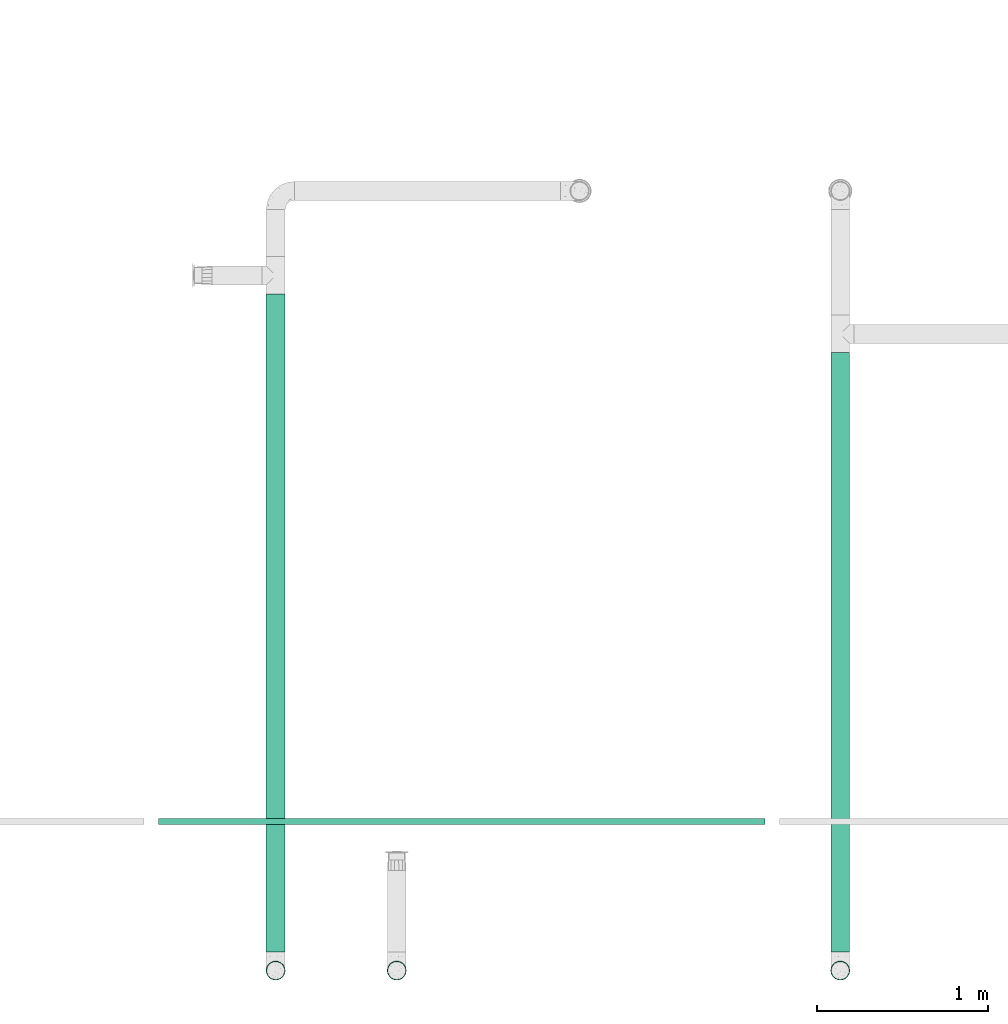
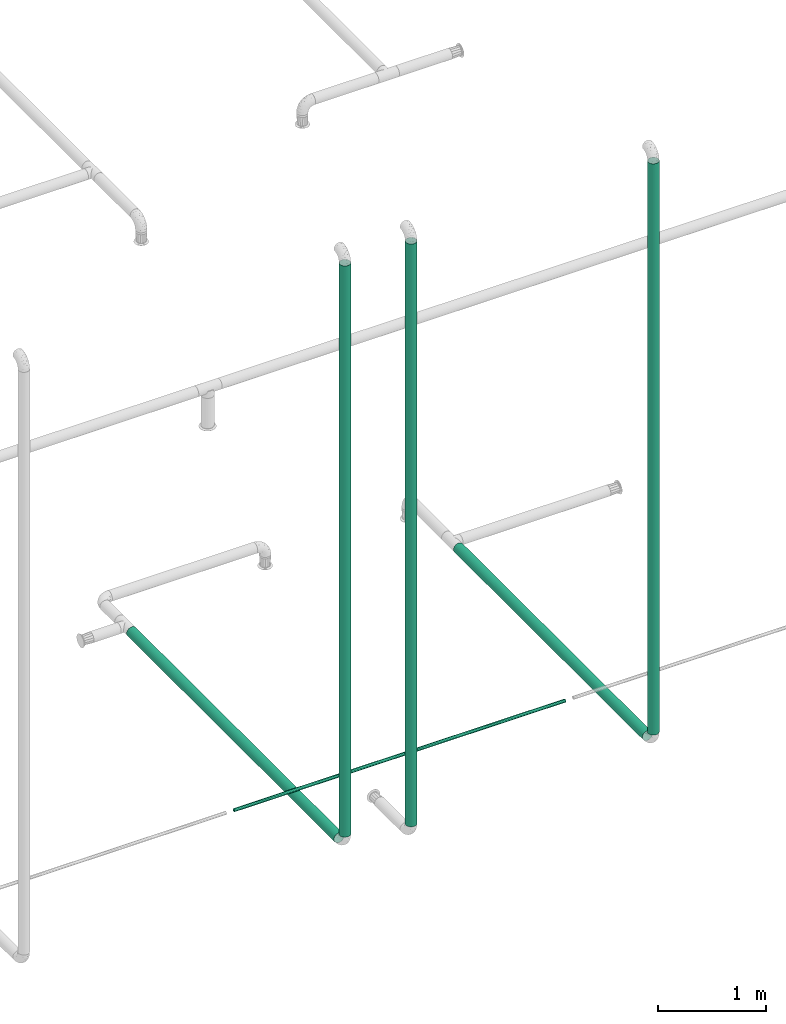
# One storey, part 14 of 123: 6 flow segments.
"""IFC2X3 building model written with IfcOpenShell, lengths in millimetres."""

from ifc_helpers import new_model, entity, si_unit, converted_unit, derived_unit, direction, frame, origin_with_axes, origin_2d_with_axis, place, context, subcontext, project, spatial, hollow_circle, extrude, source, transform, mapped, material, layer, layer_set, layer_usage, type_object, element, save


model = new_model("IFC2X3")

# Units and contexts
model_context = context("Model", 3, precision=1e-05, world=origin_with_axes(), true_north=direction((0.0, 1.0)))
body_context = subcontext(model_context, "Body", "Model", "MODEL_VIEW")
ifc_project = project(units=[si_unit("AREAUNIT", "SQUARE_METRE"), si_unit("VOLUMEUNIT", "CUBIC_METRE", prefix="DECI"), si_unit("TIMEUNIT", "SECOND"), si_unit("THERMODYNAMICTEMPERATUREUNIT", "DEGREE_CELSIUS"), si_unit("PRESSUREUNIT", "PASCAL"), si_unit("MASSUNIT", "GRAM", prefix="KILO"), si_unit("LENGTHUNIT", "METRE", prefix="MILLI"), si_unit("POWERUNIT", "WATT"), si_unit("ELECTRICCURRENTUNIT", "AMPERE"), si_unit("ELECTRICVOLTAGEUNIT", "VOLT"), derived_unit("VOLUMETRICFLOWRATEUNIT", [(si_unit("VOLUMEUNIT", "CUBIC_METRE", prefix="DECI"), 1), (si_unit("TIMEUNIT", "SECOND"), -1)]), derived_unit("LINEARVELOCITYUNIT", [(si_unit("LENGTHUNIT", "METRE"), 1), (si_unit("TIMEUNIT", "SECOND"), -1)]), derived_unit("MASSDENSITYUNIT", [(si_unit("MASSUNIT", "GRAM", prefix="KILO"), 1), (si_unit("VOLUMEUNIT", "CUBIC_METRE"), -1)]), converted_unit("PLANEANGLEUNIT", "DEGREE", entity("IfcRatioMeasure", 0.01745), si_unit("PLANEANGLEUNIT", "RADIAN"), dimensions=[0, 0, 0, 0, 0, 0, 0])], contexts=[model_context])

# Site, building, storey
site_placement = place(None, origin_with_axes())
site = spatial("IfcSite", under=ifc_project, at=site_placement, CompositionType="ELEMENT")
building_placement = place(site_placement, origin_with_axes())
building = spatial("IfcBuilding", under=site, at=building_placement, Name="mc-building", CompositionType="ELEMENT")
storey_placement = place(building_placement, origin_with_axes())
storey = spatial("IfcBuildingStorey", under=building, at=storey_placement, Name="1. Korrus", CompositionType="ELEMENT", Elevation=0.0)

# Flow segments
ifc_material_1 = material(Name="FZ1")
ifc_layer_1 = layer(ifc_material_1, 0.0)
ifc_layer_set_1 = layer_set([ifc_layer_1], Name="FZ1")
ifc_layer_usage_1 = layer_usage(ifc_layer_set_1, "AXIS1", "POSITIVE", 0.0)
duct_segment_type_1 = type_object("IfcDuctSegmentType", Name="Safe", PredefinedType="RIGIDSEGMENT")
shared_shape_1 = source(origin_with_axes(), body_context, "Body", "SweptSolid", [
    extrude(hollow_circle(Radius=55.0, WallThickness=2.0, at=origin_2d_with_axis()), frame((0.0, 0.0, 0.0), z_axis=(1.0, 0.0, 0.0), x_axis=(0.0, 1.0, 0.0)), (0.0, 0.0, 1.0), 6595.0),
])
flow_segment_1_placement = place(storey_placement, frame((27194.49649, -687.64676, 2410.0), z_axis=(0.0, 1.0, 0.0), x_axis=(0.0, 0.0, 1.0)))
element("IfcFlowSegment", 1, at=flow_segment_1_placement, inside=storey, type_object=duct_segment_type_1, material=ifc_layer_usage_1, Name="Safe", context=body_context, shape_type="MappedRepresentation", body=[
    mapped(shared_shape_1, transform((0.0, 0.0, 0.0), scale=1.0)),
])
duct_segment_type_2 = type_object("IfcDuctSegmentType", PredefinedType="RIGIDSEGMENT")
shared_shape_2 = source(origin_with_axes(), body_context, "Body", "SweptSolid", [
    extrude(hollow_circle(Radius=55.0, WallThickness=2.0, at=origin_2d_with_axis()), frame((0.0, 0.0, 0.0), z_axis=(1.0, 0.0, 0.0), x_axis=(0.0, 1.0, 0.0)), (0.0, 0.0, 1.0), 3844.9),
])
flow_segment_2_placement = place(storey_placement, frame((26486.51753, -577.64676, 2430.0), z_axis=(0.0, 0.0, 1.0), x_axis=(0.0, 1.0, 0.0)))
element("IfcFlowSegment", 2, at=flow_segment_2_placement, inside=storey, type_object=duct_segment_type_2, material=ifc_layer_usage_1, context=body_context, shape_type="MappedRepresentation", body=[
    mapped(shared_shape_2, transform((0.0, 0.0, 0.0), scale=1.0)),
])
shared_shape_3 = source(origin_with_axes(), body_context, "Body", "SweptSolid", [
    extrude(hollow_circle(Radius=55.0, WallThickness=2.0, at=origin_2d_with_axis()), frame((0.0, 0.0, 0.0), z_axis=(1.0, 0.0, 0.0), x_axis=(0.0, 1.0, 0.0)), (0.0, 0.0, 1.0), 6465.0),
])
for number, where, z_axis, x_axis in (
    (3, (26486.51753, -687.64676, 2540.0), (0.0, 1.0, 0.0), (0.0, 0.0, 1.0)),
    (4, (29788.00747, -687.64676, 2540.0), (0.0, 1.0, 0.0), (0.0, 0.0, 1.0)),
):
    element("IfcFlowSegment", number, at=place(storey_placement, frame(where, z_axis=z_axis, x_axis=x_axis)), inside=storey, type_object=duct_segment_type_2, material=ifc_layer_usage_1, context=body_context, shape_type="MappedRepresentation", body=[
        mapped(shared_shape_3, transform((0.0, 0.0, 0.0), scale=1.0)),
    ])
shared_shape_4 = source(origin_with_axes(), body_context, "Body", "SweptSolid", [
    extrude(hollow_circle(Radius=55.0, WallThickness=2.0, at=origin_2d_with_axis()), frame((0.0, 0.0, 0.0), z_axis=(1.0, 0.0, 0.0), x_axis=(0.0, 1.0, 0.0)), (0.0, 0.0, 1.0), 3503.0),
])
flow_segment_3_placement = place(storey_placement, frame((29788.00747, -577.64676, 2430.0), z_axis=(0.0, 0.0, 1.0), x_axis=(0.0, 1.0, 0.0)))
element("IfcFlowSegment", 5, at=flow_segment_3_placement, inside=storey, type_object=duct_segment_type_2, material=ifc_layer_usage_1, context=body_context, shape_type="MappedRepresentation", body=[
    mapped(shared_shape_4, transform((0.0, 0.0, 0.0), scale=1.0)),
])
ifc_material_2 = material(Name="Steel")
ifc_layer_2 = layer(ifc_material_2, 0.0)
ifc_layer_set_2 = layer_set([ifc_layer_2], Name="Steel")
ifc_layer_usage_2 = layer_usage(ifc_layer_set_2, "AXIS1", "POSITIVE", 0.0)
pipe_segment_type = type_object("IfcPipeSegmentType", PredefinedType="RIGIDSEGMENT")
shared_shape_5 = source(origin_with_axes(), body_context, "Body", "SweptSolid", [
    extrude(hollow_circle(Radius=17.5, WallThickness=2.0, at=origin_2d_with_axis()), frame((0.0, 0.0, 0.0), z_axis=(1.0, 0.0, 0.0), x_axis=(0.0, 1.0, 0.0)), (0.0, 0.0, 1.0), 3546.3),
])
flow_segment_4_placement = place(storey_placement, frame((25800.21447, 185.02869, 2518.78858), z_axis=(0.0, 0.0, 1.0), x_axis=(1.0, 0.0, 0.0)))
element("IfcFlowSegment", 6, at=flow_segment_4_placement, inside=storey, type_object=pipe_segment_type, material=ifc_layer_usage_2, context=body_context, shape_type="MappedRepresentation", body=[
    mapped(shared_shape_5, transform((0.0, 0.0, 0.0), scale=1.0)),
])

save(model, "model.ifc")
